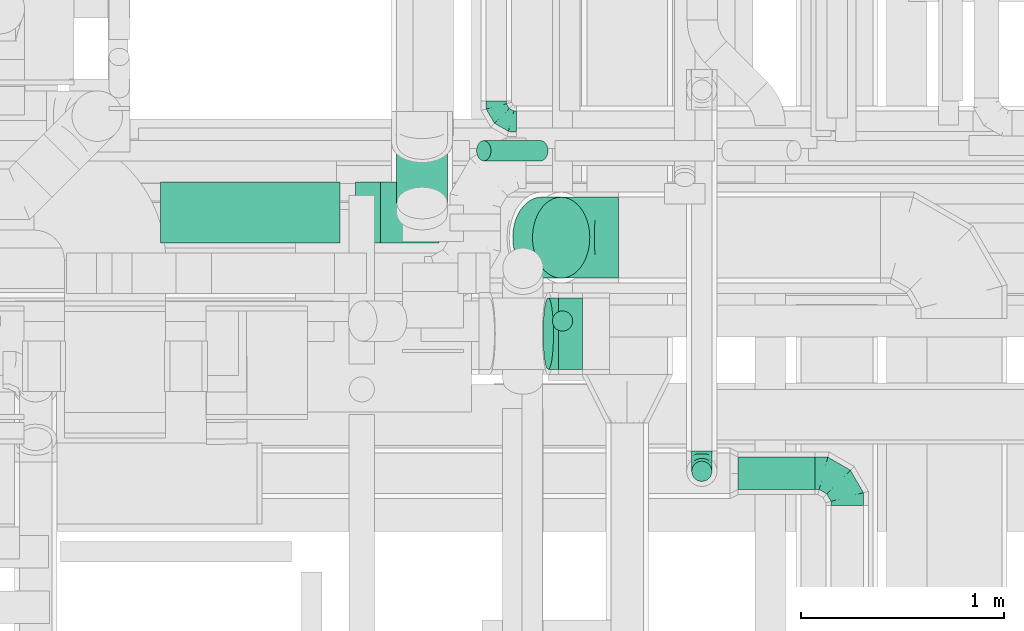
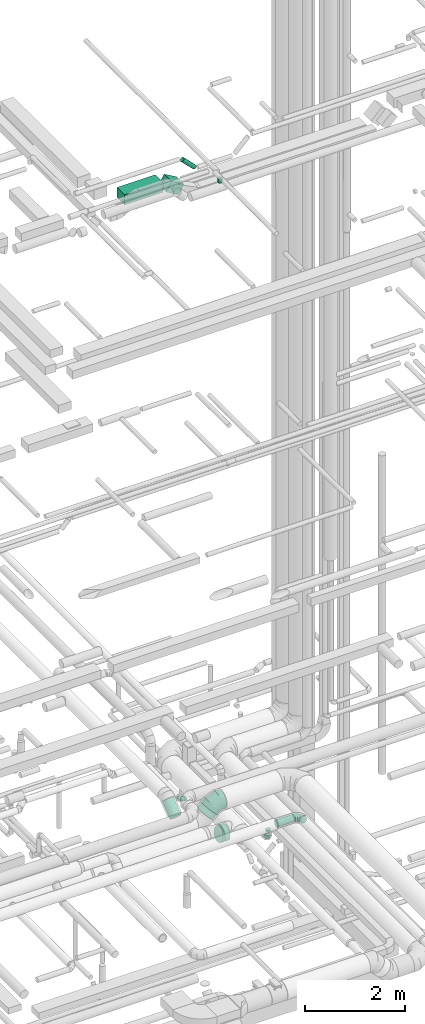
# One storey, part 254 of 337: 8 flow segments, 6 flow fittings.
"""IFC2X3 building model written with IfcOpenShell, lengths in millimetres."""

import ifcopenshell
import ifcopenshell.guid

model = None  # the IFC model being written
_history = None  # IfcOwnerHistory: only IFC2X3 demands one
_inside = {}  # id of a spatial element -> (the spatial element, [elements in it])
_under = {}  # id of a project, library or spatial element -> (it, [spatial elements below it])
_declared = {}  # id of a project -> (the project, [libraries it declares])
_typed = {}  # id of a type object -> (the type object, [elements of that type])
_made_of = {}  # id of a material, layer set ... -> (it, [elements and type objects made of it])


def new_model(schema):
    """Start an empty IFC model of exactly this schema.

    Asked for "IFC4X3", IfcOpenShell would pick the latest addendum, in which some entities
    have other attributes; the version numbers below select the first issue.
    IFC2X3 requires an IfcOwnerHistory on every rooted entity: one is made here for all.
    """
    global model, _history
    if schema == "IFC4X3":
        model = ifcopenshell.file(schema_version=(4, 3, 0, 0))
    else:
        model = ifcopenshell.file(schema=schema)
    _inside.clear()
    _under.clear()
    _declared.clear()
    _typed.clear()
    _made_of.clear()
    _history = None
    if model.schema == "IFC2X3":
        org = make("IfcOrganization", Name="unknown")
        user = make(
            "IfcPersonAndOrganization",
            ThePerson=make("IfcPerson", FamilyName="unknown"),
            TheOrganization=org,
        )
        app = make(
            "IfcApplication",
            ApplicationDeveloper=org,
            Version="unknown",
            ApplicationFullName="unknown",
            ApplicationIdentifier="unknown",
        )
        _history = make(
            "IfcOwnerHistory",
            OwningUser=user,
            OwningApplication=app,
            ChangeAction="ADDED",
            CreationDate=0,
        )
    return model


def make(cls, **values):
    """One entity of the class cls with the attributes given. An attribute that is None is left unset."""
    return model.create_entity(
        cls, **{name: value for name, value in values.items() if value is not None}
    )


def entity(cls, *values):
    """Any entity or typed value of the class cls, its attributes in the order of the schema. None: left unset."""
    e = model.create_entity(cls)
    for i, value in enumerate(values):
        if value is not None:
            e[i] = value
    return e


def rooted(cls, **values):
    """An entity with a GlobalId (a new one), such as an element, a storey or a relation."""
    return make(cls, GlobalId=ifcopenshell.guid.new(), OwnerHistory=_history, **values)


def si_unit(unit_type, name, prefix=None):
    """IfcSIUnit, for example si_unit("LENGTHUNIT", "METRE", prefix="MILLI")."""
    return make("IfcSIUnit", UnitType=unit_type, Prefix=prefix, Name=name)


def converted_unit(unit_type, name, factor, base, dimensions=None, offset=None):
    """IfcConversionBasedUnit, such as the inch: factor (a typed value) times the base unit."""
    return make(
        "IfcConversionBasedUnit"
        if offset is None
        else "IfcConversionBasedUnitWithOffset",
        ConversionOffset=offset,
        Dimensions=None
        if dimensions is None
        else entity("IfcDimensionalExponents", *dimensions),
        UnitType=unit_type,
        Name=name,
        ConversionFactor=make(
            "IfcMeasureWithUnit", ValueComponent=factor, UnitComponent=base
        ),
    )


def derived_unit(unit_type, elements):
    """IfcDerivedUnit: a product of units, each with its exponent."""
    return make(
        "IfcDerivedUnit",
        Elements=[
            make("IfcDerivedUnitElement", Unit=unit, Exponent=power)
            for unit, power in elements
        ],
        UnitType=unit_type,
    )


def assignment(units):
    """IfcUnitAssignment: the units of a project."""
    return None if units is None else make("IfcUnitAssignment", Units=units)


def point(xyz):
    """IfcCartesianPoint."""
    return None if xyz is None else make("IfcCartesianPoint", Coordinates=xyz)


def direction(xyz):
    """IfcDirection."""
    return None if xyz is None else make("IfcDirection", DirectionRatios=xyz)


def frame(location, z_axis=None, x_axis=None):
    """IfcAxis2Placement3D, a coordinate frame: its origin and axes. An axis left out is left unset."""
    return make(
        "IfcAxis2Placement3D",
        Location=point(location),
        Axis=direction(z_axis),
        RefDirection=direction(x_axis),
    )


def frame_2d(location, x_axis=None):
    """IfcAxis2Placement2D, a coordinate frame in the plane: its origin and x axis."""
    return make(
        "IfcAxis2Placement2D", Location=point(location), RefDirection=direction(x_axis)
    )


def origin():
    """The frame at (0, 0, 0) with its axes left unset."""
    return frame((0.0, 0.0, 0.0))


def origin_2d_with_axis():
    """The frame at (0, 0) in the plane with the x axis (1, 0) written out."""
    return frame_2d((0.0, 0.0), x_axis=(1.0, 0.0))


def place(relative_to, where):
    """IfcLocalPlacement: puts the frame where relative to a parent placement (None: the world)."""
    return make(
        "IfcLocalPlacement", PlacementRelTo=relative_to, RelativePlacement=where
    )


def context(
    kind, dimensions, precision=None, world=None, true_north=None, identifier=None
):
    """IfcGeometricRepresentationContext, for example the 3D "Model" context."""
    return make(
        "IfcGeometricRepresentationContext",
        ContextIdentifier=identifier,
        ContextType=kind,
        CoordinateSpaceDimension=dimensions,
        Precision=precision,
        WorldCoordinateSystem=world,
        TrueNorth=true_north,
    )


def subcontext(parent, identifier, kind, view, scale=None):
    """IfcGeometricRepresentationSubContext, for example "Body" below "Model"."""
    return make(
        "IfcGeometricRepresentationSubContext",
        ContextIdentifier=identifier,
        ContextType=kind,
        ParentContext=parent,
        TargetScale=scale,
        TargetView=view,
    )


def project(units=None, contexts=None):
    """IfcProject with its units and contexts."""
    return rooted(
        "IfcProject",
        Name="project",
        RepresentationContexts=contexts,
        UnitsInContext=assignment(units),
    )


def spatial(cls, under=None, at=None, **own):
    """A site, building, storey or space (cls), placed at a placement, below another one or the project."""
    s = rooted(cls, ObjectPlacement=at, **own)
    if under is not None:
        _under.setdefault(under.id(), (under, []))[1].append(s)
    return s


def profile(cls, at=None, kind="AREA", **sizes):
    """A parametric profile (cls). Its sizes go by their IFC names, for example OverallWidth=200.0."""
    return make(cls, ProfileType=kind, Position=at, **sizes)


def rectangle(**sizes):
    """IfcRectangleProfileDef."""
    return profile("IfcRectangleProfileDef", **sizes)


def circle(**sizes):
    """IfcCircleProfileDef."""
    return profile("IfcCircleProfileDef", **sizes)


def extrude(swept, where, along, depth):
    """IfcExtrudedAreaSolid: the profile swept, set in the frame where, extruded along a direction by depth."""
    return make(
        "IfcExtrudedAreaSolid",
        SweptArea=swept,
        Position=where,
        ExtrudedDirection=direction(along),
        Depth=depth,
    )


def faces_of(points, faces, orient=None, outer=None):
    """IfcFace entities. A face is a list of loops; a loop is a list of indices into points, from 0.

    orient and outer hold one flag for each loop. By default every Orientation is true, the
    first loop of a face is its IfcFaceOuterBound and the others are IfcFaceBound.
    """
    made = []
    for i, loops in enumerate(faces):
        bounds = []
        for j, loop in enumerate(loops):
            is_outer = j == 0 if outer is None else outer[i][j]
            bounds.append(
                make(
                    "IfcFaceOuterBound" if is_outer else "IfcFaceBound",
                    Bound=make("IfcPolyLoop", Polygon=[points[k] for k in loop]),
                    Orientation=True if orient is None else orient[i][j],
                )
            )
        made.append(make("IfcFace", Bounds=bounds))
    return made


def faceted_brep(points, faces, orient=None, outer=None, voids=None):
    """IfcFacetedBrep: a solid bounded by flat faces; with voids (closed shells), ...WithVoids."""
    shared = [point(p) for p in points]
    hull = make("IfcClosedShell", CfsFaces=faces_of(shared, faces, orient, outer))
    if voids is None:
        return make("IfcFacetedBrep", Outer=hull)
    return make(
        "IfcFacetedBrepWithVoids",
        Outer=hull,
        Voids=[
            make(cls, CfsFaces=faces_of(shared, fs, o, b)) for cls, fs, o, b in voids
        ],
    )


def shape(context_of_items, identifier, shape_type, items):
    """IfcShapeRepresentation: the items that make up one representation, for example the "Body"."""
    return make(
        "IfcShapeRepresentation",
        ContextOfItems=context_of_items,
        RepresentationIdentifier=identifier,
        RepresentationType=shape_type,
        Items=items,
    )


def source(mapping_origin, context_of_items, identifier, shape_type, items):
    """IfcRepresentationMap: a shape defined once, which mapped items show again and again."""
    return make(
        "IfcRepresentationMap",
        MappingOrigin=mapping_origin,
        MappedRepresentation=shape(context_of_items, identifier, shape_type, items),
    )


def transform(
    local_origin,
    x_axis=None,
    y_axis=None,
    z_axis=None,
    scale=None,
    scale2=None,
    scale3=None,
    uniform=True,
):
    """IfcCartesianTransformationOperator3D, or its non-uniform kind. x_axis, y_axis, z_axis: its Axis1, 2, 3."""
    if uniform:
        return make(
            "IfcCartesianTransformationOperator3D",
            Axis1=direction(x_axis),
            Axis2=direction(y_axis),
            LocalOrigin=point(local_origin),
            Scale=scale,
            Axis3=direction(z_axis),
        )
    return make(
        "IfcCartesianTransformationOperator3DnonUniform",
        Axis1=direction(x_axis),
        Axis2=direction(y_axis),
        LocalOrigin=point(local_origin),
        Scale=scale,
        Axis3=direction(z_axis),
        Scale2=scale2,
        Scale3=scale3,
    )


def mapped(mapping_source, mapping_target):
    """IfcMappedItem: shows the shape of a source again, moved by a transform."""
    return make(
        "IfcMappedItem", MappingSource=mapping_source, MappingTarget=mapping_target
    )


def material(Name=None, Category=None):
    """IfcMaterial."""
    return make("IfcMaterial", Name=Name, Category=Category)


def made_of(thing, what):
    """Note that an element or type object is made of a material, layer set ...; save() writes the relation."""
    if what is not None:
        _made_of.setdefault(what.id(), (what, []))[1].append(thing)
    return thing


def type_object(cls, material=None, **own):
    """A type object (cls), such as IfcWallType, which elements share."""
    return made_of(rooted(cls, **own), material)


def type_shapes(of_type, sources):
    """Give a type object the sources (RepresentationMaps) that its elements show as mapped items."""
    of_type.RepresentationMaps = sources


def element(
    cls,
    number,
    at=None,
    inside=None,
    cuts=None,
    type_object=None,
    material=None,
    context=None,
    identifier="Body",
    shape_type=None,
    held_by="IfcProductDefinitionShape",
    body=None,
    shapes=None,
    **own,
):
    """One element of the class cls, such as IfcWall. Its Tag is "e" and its number.

    at: its placement. inside: the storey or other place that contains it. cuts: it is an
    opening in that element (IfcRelVoidsElement). A single representation is given by context,
    identifier, shape_type and body (its items); several are given by shapes. held_by: the class
    of the entity that holds the representations. save() writes the other relations.
    """
    e = rooted(cls, Tag="e%d" % number, ObjectPlacement=at, **own)
    if body is not None:
        shapes = [shape(context, identifier, shape_type, body)]
    if shapes is not None:
        e.Representation = make(held_by, Representations=shapes)
    if inside is not None:
        _inside.setdefault(inside.id(), (inside, []))[1].append(e)
    if cuts is not None:
        rooted(
            "IfcRelVoidsElement", RelatingBuildingElement=cuts, RelatedOpeningElement=e
        )
    if type_object is not None:
        _typed.setdefault(type_object.id(), (type_object, []))[1].append(e)
    return made_of(e, material)


def aggregate(whole, parts):
    """IfcRelAggregates: a whole, such as a stair, and the parts it consists of."""
    return rooted("IfcRelAggregates", RelatingObject=whole, RelatedObjects=parts)


def save(model, path):
    """Write the relations noted so far, then the file.

    IfcRelAggregates (storeys below a building ...), IfcRelContainedInSpatialStructure (elements
    in a storey), IfcRelDefinesByType, IfcRelAssociatesMaterial and IfcRelDeclares: one each for
    every whole, place, type object, material and project.
    """
    for whole, parts in _under.values():
        aggregate(whole, parts)
    for where, things in _inside.values():
        rooted(
            "IfcRelContainedInSpatialStructure",
            RelatedElements=things,
            RelatingStructure=where,
        )
    for kind, things in _typed.values():
        rooted("IfcRelDefinesByType", RelatedObjects=things, RelatingType=kind)
    for what, things in _made_of.values():
        rooted("IfcRelAssociatesMaterial", RelatedObjects=things, RelatingMaterial=what)
    for by, libraries in _declared.values():
        rooted("IfcRelDeclares", RelatingContext=by, RelatedDefinitions=libraries)
    model.write(path)


model = new_model("IFC2X3")

# Units and contexts
model_context = context("Model", 3, precision=0.01, world=origin(), true_north=direction((6.12303176911189e-17, 1.0)))
body_context = subcontext(model_context, "Body", "Model", "MODEL_VIEW")
ifc_project = project(units=[si_unit("LENGTHUNIT", "METRE", prefix="MILLI"), si_unit("AREAUNIT", "SQUARE_METRE"), si_unit("VOLUMEUNIT", "CUBIC_METRE"), converted_unit("PLANEANGLEUNIT", "DEGREE", entity("IfcRatioMeasure", 0.0174532925199433), si_unit("PLANEANGLEUNIT", "RADIAN"), dimensions=[0, 0, 0, 0, 0, 0, 0]), si_unit("MASSUNIT", "GRAM", prefix="KILO"), derived_unit("MASSDENSITYUNIT", [(si_unit("MASSUNIT", "GRAM", prefix="KILO"), 1), (si_unit("LENGTHUNIT", "METRE"), -3)]), derived_unit("MOMENTOFINERTIAUNIT", [(si_unit("LENGTHUNIT", "METRE"), 4)]), si_unit("TIMEUNIT", "SECOND"), si_unit("FREQUENCYUNIT", "HERTZ"), si_unit("THERMODYNAMICTEMPERATUREUNIT", "DEGREE_CELSIUS"), derived_unit("THERMALTRANSMITTANCEUNIT", [(si_unit("MASSUNIT", "GRAM", prefix="KILO"), 1), (si_unit("THERMODYNAMICTEMPERATUREUNIT", "KELVIN"), -1), (si_unit("TIMEUNIT", "SECOND"), -3)]), derived_unit("VOLUMETRICFLOWRATEUNIT", [(si_unit("LENGTHUNIT", "METRE"), 3), (si_unit("TIMEUNIT", "SECOND"), -1)]), derived_unit("MASSFLOWRATEUNIT", [(si_unit("MASSUNIT", "GRAM", prefix="KILO"), 1), (si_unit("TIMEUNIT", "SECOND"), -1)]), derived_unit("ROTATIONALFREQUENCYUNIT", [(si_unit("TIMEUNIT", "SECOND"), -1)]), si_unit("ELECTRICCURRENTUNIT", "AMPERE"), si_unit("ELECTRICVOLTAGEUNIT", "VOLT"), si_unit("POWERUNIT", "WATT"), si_unit("FORCEUNIT", "NEWTON", prefix="KILO"), si_unit("ILLUMINANCEUNIT", "LUX"), si_unit("LUMINOUSFLUXUNIT", "LUMEN"), si_unit("LUMINOUSINTENSITYUNIT", "CANDELA"), derived_unit("USERDEFINED", [(si_unit("MASSUNIT", "GRAM", prefix="KILO"), -1), (si_unit("LENGTHUNIT", "METRE"), -2), (si_unit("TIMEUNIT", "SECOND"), 3), (si_unit("LUMINOUSFLUXUNIT", "LUMEN"), 1)]), derived_unit("LINEARVELOCITYUNIT", [(si_unit("LENGTHUNIT", "METRE"), 1), (si_unit("TIMEUNIT", "SECOND"), -1)]), si_unit("PRESSUREUNIT", "PASCAL"), derived_unit("USERDEFINED", [(si_unit("LENGTHUNIT", "METRE"), -2), (si_unit("MASSUNIT", "GRAM", prefix="KILO"), 1), (si_unit("TIMEUNIT", "SECOND"), -2)]), derived_unit("LINEARFORCEUNIT", [(si_unit("MASSUNIT", "GRAM", prefix="KILO"), 1), (si_unit("LENGTHUNIT", "METRE"), 1), (si_unit("TIMEUNIT", "SECOND"), -2), (si_unit("LENGTHUNIT", "METRE"), -1)]), derived_unit("PLANARFORCEUNIT", [(si_unit("MASSUNIT", "GRAM", prefix="KILO"), 1), (si_unit("LENGTHUNIT", "METRE"), 1), (si_unit("TIMEUNIT", "SECOND"), -2), (si_unit("LENGTHUNIT", "METRE"), -2)])], contexts=[model_context])

# Site, building, storey
site_placement = place(None, origin())
site = spatial("IfcSite", under=ifc_project, at=site_placement, CompositionType="ELEMENT")
building_placement = place(site_placement, origin())
building = spatial("IfcBuilding", under=site, at=building_placement, CompositionType="ELEMENT")
storey_placement = place(building_placement, origin())
storey = spatial("IfcBuildingStorey", under=building, at=storey_placement, CompositionType="ELEMENT", Elevation=0.0)

# Flow segments
duct_segment_type_1 = type_object("IfcDuctSegmentType", PredefinedType="NOTDEFINED")
flow_segment_1_placement = place(storey_placement, frame((62344.65, 9724.07, 18850.0)))
element("IfcFlowSegment", 1, at=flow_segment_1_placement, inside=storey, type_object=duct_segment_type_1, context=body_context, shape_type="SweptSolid", body=[
    extrude(rectangle(XDim=886.526564663121, YDim=300.0, at=origin_2d_with_axis()), frame((443.26, 150.0, 0.0)), (0.0, 0.0, 1.0), 249.999999999999),
])
flow_segment_2_placement = place(storey_placement, frame((63306.03, 9724.07, 18663.36)))
element("IfcFlowSegment", 2, at=flow_segment_2_placement, inside=storey, type_object=duct_segment_type_1, context=body_context, shape_type="SweptSolid", body=[
    extrude(rectangle(XDim=250.000000000003, YDim=300.0, at=frame_2d((0.0, 0.0), x_axis=(0.0, 1.0))), frame((62.38, 150.0, 274.95), z_axis=(0.86659261286726, 0.0, -0.499016275610221), x_axis=(0.0, 1.0, 0.0)), (0.0, 0.0, 1.0), 333.908822659735),
])
duct_segment_type_2 = type_object("IfcDuctSegmentType", PredefinedType="NOTDEFINED")
flow_segment_3_placement = place(storey_placement, frame((64277.72, 9286.98, 18955.0)))
element("IfcFlowSegment", 3, at=flow_segment_3_placement, inside=storey, type_object=duct_segment_type_2, context=body_context, shape_type="SweptSolid", body=[
    extrude(circle(Radius=50.0, at=origin_2d_with_axis()), frame((51.6, 51.6, 0.0)), (0.0, 0.0, 1.0), 94.9999999999871),
])
flow_segment_4_placement = place(storey_placement, frame((63903.4, 10127.45, 18812.34)))
element("IfcFlowSegment", 4, at=flow_segment_4_placement, inside=storey, type_object=duct_segment_type_2, context=body_context, shape_type="SweptSolid", body=[
    extrude(circle(Radius=50.0, at=origin_2d_with_axis()), frame((318.37, 51.6, 36.95), z_axis=(-0.707106781186552, 0.0, 0.707106781186543), x_axis=(0.0, 1.0, 0.0)), (0.0, 0.0, 1.0), 397.989898732217),
])
flow_segment_5_placement = place(storey_placement, frame((64081.65, 9548.4, 3142.18)))
element("IfcFlowSegment", 5, at=flow_segment_5_placement, inside=storey, type_object=duct_segment_type_2, context=body_context, shape_type="SweptSolid", body=[
    extrude(circle(Radius=200.0, at=origin_2d_with_axis()), frame((143.02, 201.6, 143.02), z_axis=(0.707106759953313, 0.0, 0.707106802419781), x_axis=(0.0, 1.0, 0.0)), (0.0, 0.0, 1.0), 138.093806996356),
])
flow_segment_6_placement = place(storey_placement, frame((64310.17, 9096.79, 2870.9)))
element("IfcFlowSegment", 6, at=flow_segment_6_placement, inside=storey, type_object=duct_segment_type_2, context=body_context, shape_type="SweptSolid", body=[
    extrude(circle(Radius=177.5, at=origin_2d_with_axis()), frame((0.0, 179.1, 179.1), z_axis=(1.0, 0.0, 0.0), x_axis=(0.0, 1.0, 0.0)), (0.0, 0.0, 1.0), 118.097986558883),
])
flow_segment_7_placement = place(storey_placement, frame((65196.4, 8505.07, 3318.4)))
element("IfcFlowSegment", 7, at=flow_segment_7_placement, inside=storey, type_object=duct_segment_type_2, context=body_context, shape_type="SweptSolid", body=[
    extrude(circle(Radius=80.0, at=origin_2d_with_axis()), frame((0.0, 81.6, 81.6), z_axis=(1.0, 0.0, 0.0), x_axis=(0.0, -1.0, 0.0)), (0.0, 0.0, 1.0), 378.271123421161),
])
flow_segment_8_placement = place(storey_placement, frame((63508.85, 9840.74, 3207.72)))
element("IfcFlowSegment", 8, at=flow_segment_8_placement, inside=storey, type_object=duct_segment_type_2, context=body_context, shape_type="SweptSolid", body=[
    extrude(circle(Radius=125.0, at=origin_2d_with_axis()), frame((126.6, 80.25, 98.75), z_axis=(0.0, 0.777218163674396, 0.629231218277192), x_axis=(1.0, 0.0, 0.0)), (0.0, 0.0, 1.0), 377.977646889818),
])

# Flow fittings
ifc_material = material()
duct_fitting_type_1 = type_object("IfcDuctFittingType", PredefinedType="NOTDEFINED", material=ifc_material)
shared_shape_1 = source(origin(), body_context, "Body", "Brep", [
    faceted_brep([(-160.0, 0.0, -80.0), (-160.0, -20.71, -77.27), (-160.0, -40.0, -69.28), (-160.0, -56.57, -56.57), (-160.0, -69.28, -40.0), (-160.0, -77.27, -20.71), (-160.0, -80.0, 0.0), (-160.0, -77.27, 20.71), (-160.0, -69.28, 40.0), (-160.0, -56.57, 56.57), (-160.0, -40.0, 69.28), (-160.0, -20.71, 77.27), (-160.0, 0.0, 80.0), (-160.0, 20.71, 77.27), (-160.0, 40.0, 69.28), (-160.0, 56.57, 56.57), (-160.0, 69.28, 40.0), (-160.0, 77.27, 20.71), (-160.0, 80.0, 0.0), (-160.0, 77.27, -20.71), (-160.0, 69.28, -40.0), (-160.0, 56.57, -56.57), (-160.0, 40.0, -69.28), (-160.0, 20.71, -77.27), (-122.68, 20.71, 77.27), (-127.85, 40.0, 69.28), (-117.13, 0.0, 80.0), (-132.29, 56.57, 56.57), (-137.83, 77.27, 20.71), (-138.56, 80.0, 0.0), (-135.69, 69.28, 40.0), (-135.69, 69.28, -40.0), (-132.29, 56.57, -56.57), (-137.83, 77.27, -20.71), (-122.68, 20.71, -77.27), (-117.13, 0.0, -80.0), (-127.85, 40.0, -69.28), (-111.58, -20.71, -77.27), (-106.41, -40.0, -69.28), (-101.97, -56.57, -56.57), (-98.56, -69.28, -40.0), (-96.42, -77.27, -20.71), (-95.69, -80.0, 0.0), (-96.42, -77.27, 20.71), (-98.56, -69.28, 40.0), (-101.97, -56.57, 56.57), (-106.41, -40.0, 69.28), (-111.58, -20.71, 77.27), (-58.03, 58.03, 77.27), (-72.15, 72.15, 69.28), (-42.87, 42.87, 80.0), (-84.28, 84.28, 56.57), (-93.59, 93.59, 40.0), (-99.44, 99.44, 20.71), (-101.44, 101.44, 0.0), (-99.44, 99.44, -20.71), (-93.59, 93.59, -40.0), (-84.28, 84.28, -56.57), (-58.03, 58.03, -77.27), (-42.87, 42.87, -80.0), (-72.15, 72.15, -69.28), (-27.71, 27.71, -77.27), (-13.59, 13.59, -69.28), (-1.46, 1.46, -56.57), (7.85, -7.85, -40.0), (13.7, -13.7, -20.71), (15.69, -15.69, 0.0), (13.7, -13.7, 20.71), (7.85, -7.85, 40.0), (-1.46, 1.46, 56.57), (-13.59, 13.59, 69.28), (-27.71, 27.71, 77.27), (-20.71, 122.68, 77.27), (-40.0, 127.85, 69.28), (0.0, 117.13, 80.0), (-56.57, 132.29, 56.57), (-69.28, 135.69, 40.0), (-77.27, 137.83, 20.71), (-80.0, 138.56, 0.0), (-77.27, 137.83, -20.71), (-69.28, 135.69, -40.0), (-56.57, 132.29, -56.57), (-20.71, 122.68, -77.27), (0.0, 117.13, -80.0), (-40.0, 127.85, -69.28), (20.71, 111.58, -77.27), (40.0, 106.41, -69.28), (56.57, 101.97, -56.57), (69.28, 98.56, -40.0), (77.27, 96.42, -20.71), (80.0, 95.69, 0.0), (77.27, 96.42, 20.71), (69.28, 98.56, 40.0), (56.57, 101.97, 56.57), (40.0, 106.41, 69.28), (20.71, 111.58, 77.27), (-20.71, 160.0, -77.27), (-40.0, 160.0, -69.28), (-56.57, 160.0, -56.57), (-69.28, 160.0, -40.0), (-77.27, 160.0, -20.71), (-80.0, 160.0, 0.0), (-77.27, 160.0, 20.71), (-69.28, 160.0, 40.0), (-56.57, 160.0, 56.57), (-40.0, 160.0, 69.28), (-20.71, 160.0, 77.27), (0.0, 160.0, 80.0), (20.71, 160.0, 77.27), (40.0, 160.0, 69.28), (56.57, 160.0, 56.57), (69.28, 160.0, 40.0), (77.27, 160.0, 20.71), (80.0, 160.0, 0.0), (77.27, 160.0, -20.71), (69.28, 160.0, -40.0), (56.57, 160.0, -56.57), (40.0, 160.0, -69.28), (20.71, 160.0, -77.27), (0.0, 160.0, -80.0)], [[[0, 1, 2, 3, 4, 5, 6, 7, 8, 9, 10, 11, 12, 13, 14, 15, 16, 17, 18, 19, 20, 21, 22, 23]], [[24, 25, 14, 13]], [[26, 24, 13, 12]], [[14, 25, 27, 15]], [[28, 29, 18, 17]], [[30, 28, 17, 16]], [[15, 27, 30, 16]], [[20, 31, 32, 21]], [[33, 31, 20, 19]], [[18, 29, 33, 19]], [[34, 35, 0, 23]], [[36, 34, 23, 22]], [[32, 36, 22, 21]], [[1, 0, 35, 37]], [[2, 1, 37, 38]], [[3, 2, 38, 39]], [[5, 4, 40, 41]], [[6, 5, 41, 42]], [[39, 40, 4, 3]], [[6, 42, 43, 7]], [[7, 43, 44, 8]], [[8, 44, 45, 9]], [[9, 45, 46, 10]], [[10, 46, 47, 11]], [[26, 12, 11, 47]], [[48, 49, 25, 24]], [[50, 48, 24, 26]], [[27, 25, 49, 51]], [[52, 53, 28, 30]], [[51, 52, 30, 27]], [[29, 28, 53, 54]], [[55, 56, 31, 33]], [[54, 55, 33, 29]], [[32, 31, 56, 57]], [[58, 59, 35, 34]], [[60, 58, 34, 36]], [[57, 60, 36, 32]], [[37, 35, 59, 61]], [[38, 37, 61, 62]], [[39, 38, 62, 63]], [[41, 40, 64, 65]], [[42, 41, 65, 66]], [[63, 64, 40, 39]], [[43, 42, 66, 67]], [[44, 43, 67, 68]], [[68, 69, 45, 44]], [[46, 45, 69, 70]], [[47, 46, 70, 71]], [[26, 47, 71, 50]], [[72, 73, 49, 48]], [[74, 72, 48, 50]], [[51, 49, 73, 75]], [[76, 77, 53, 52]], [[75, 76, 52, 51]], [[54, 53, 77, 78]], [[79, 80, 56, 55]], [[78, 79, 55, 54]], [[57, 56, 80, 81]], [[82, 83, 59, 58]], [[84, 82, 58, 60]], [[81, 84, 60, 57]], [[61, 59, 83, 85]], [[62, 61, 85, 86]], [[63, 62, 86, 87]], [[65, 64, 88, 89]], [[66, 65, 89, 90]], [[87, 88, 64, 63]], [[67, 66, 90, 91]], [[68, 67, 91, 92]], [[92, 93, 69, 68]], [[70, 69, 93, 94]], [[71, 70, 94, 95]], [[50, 71, 95, 74]], [[96, 97, 98, 99, 100, 101, 102, 103, 104, 105, 106, 107, 108, 109, 110, 111, 112, 113, 114, 115, 116, 117, 118, 119]], [[72, 74, 107, 106]], [[73, 72, 106, 105]], [[75, 73, 105, 104]], [[77, 76, 103, 102]], [[78, 77, 102, 101]], [[75, 104, 103, 76]], [[78, 101, 100, 79]], [[79, 100, 99, 80]], [[80, 99, 98, 81]], [[84, 97, 96, 82]], [[82, 96, 119, 83]], [[84, 81, 98, 97]], [[118, 117, 86, 85]], [[119, 118, 85, 83]], [[116, 87, 86, 117]], [[88, 115, 114, 89]], [[89, 114, 113, 90]], [[115, 88, 87, 116]], [[112, 111, 92, 91]], [[113, 112, 91, 90]], [[111, 110, 93, 92]], [[95, 94, 109, 108]], [[74, 95, 108, 107]], [[110, 109, 94, 93]]]),
])
type_shapes(duct_fitting_type_1, [shared_shape_1])
flow_fitting_1_placement = place(storey_placement, frame((65734.68, 8586.67, 3400.0), z_axis=(0.0, 0.0, 1.0), x_axis=(0.0, 1.0, 0.0)))
element("IfcFlowFitting", 9, at=flow_fitting_1_placement, inside=storey, type_object=duct_fitting_type_1, material=ifc_material, context=body_context, shape_type="MappedRepresentation", body=[
    mapped(shared_shape_1, transform((0.0, 0.0, 0.0), scale=1.0)),
])
duct_fitting_type_2 = type_object("IfcDuctFittingType", PredefinedType="NOTDEFINED", material=ifc_material)
shared_shape_2 = source(origin(), body_context, "Body", "Brep", [
    faceted_brep([(-100.0, 0.0, -50.0), (-100.0, -12.94, -48.3), (-100.0, -25.0, -43.3), (-100.0, -35.36, -35.36), (-100.0, -43.3, -25.0), (-100.0, -48.3, -12.94), (-100.0, -50.0, 0.0), (-100.0, -48.3, 12.94), (-100.0, -43.3, 25.0), (-100.0, -35.36, 35.36), (-100.0, -25.0, 43.3), (-100.0, -12.94, 48.3), (-100.0, 0.0, 50.0), (-100.0, 12.94, 48.3), (-100.0, 25.0, 43.3), (-100.0, 35.36, 35.36), (-100.0, 43.3, 25.0), (-100.0, 48.3, 12.94), (-100.0, 50.0, 0.0), (-100.0, 48.3, -12.94), (-100.0, 43.3, -25.0), (-100.0, 35.36, -35.36), (-100.0, 25.0, -43.3), (-100.0, 12.94, -48.3), (-76.67, 12.94, 48.3), (-79.9, 25.0, 43.3), (-73.21, 0.0, 50.0), (-82.68, 35.36, 35.36), (-86.15, 48.3, 12.94), (-86.6, 50.0, 0.0), (-84.81, 43.3, 25.0), (-84.81, 43.3, -25.0), (-82.68, 35.36, -35.36), (-86.15, 48.3, -12.94), (-76.67, 12.94, -48.3), (-73.21, 0.0, -50.0), (-79.9, 25.0, -43.3), (-69.74, -12.94, -48.3), (-66.51, -25.0, -43.3), (-63.73, -35.36, -35.36), (-61.6, -43.3, -25.0), (-60.26, -48.3, -12.94), (-59.81, -50.0, 0.0), (-60.26, -48.3, 12.94), (-61.6, -43.3, 25.0), (-63.73, -35.36, 35.36), (-66.51, -25.0, 43.3), (-69.74, -12.94, 48.3), (-36.27, 36.27, 48.3), (-45.1, 45.1, 43.3), (-26.79, 26.79, 50.0), (-52.68, 52.68, 35.36), (-58.49, 58.49, 25.0), (-62.15, 62.15, 12.94), (-63.4, 63.4, 0.0), (-62.15, 62.15, -12.94), (-58.49, 58.49, -25.0), (-52.68, 52.68, -35.36), (-36.27, 36.27, -48.3), (-26.79, 26.79, -50.0), (-45.1, 45.1, -43.3), (-17.32, 17.32, -48.3), (-8.49, 8.49, -43.3), (-0.91, 0.91, -35.36), (4.9, -4.9, -25.0), (8.56, -8.56, -12.94), (9.81, -9.81, 0.0), (8.56, -8.56, 12.94), (4.9, -4.9, 25.0), (-0.91, 0.91, 35.36), (-8.49, 8.49, 43.3), (-17.32, 17.32, 48.3), (-12.94, 76.67, 48.3), (-25.0, 79.9, 43.3), (0.0, 73.21, 50.0), (-35.36, 82.68, 35.36), (-43.3, 84.81, 25.0), (-48.3, 86.15, 12.94), (-50.0, 86.6, 0.0), (-48.3, 86.15, -12.94), (-43.3, 84.81, -25.0), (-35.36, 82.68, -35.36), (-12.94, 76.67, -48.3), (0.0, 73.21, -50.0), (-25.0, 79.9, -43.3), (12.94, 69.74, -48.3), (25.0, 66.51, -43.3), (35.36, 63.73, -35.36), (43.3, 61.6, -25.0), (48.3, 60.26, -12.94), (50.0, 59.81, 0.0), (48.3, 60.26, 12.94), (43.3, 61.6, 25.0), (35.36, 63.73, 35.36), (25.0, 66.51, 43.3), (12.94, 69.74, 48.3), (-12.94, 100.0, -48.3), (-25.0, 100.0, -43.3), (-35.36, 100.0, -35.36), (-43.3, 100.0, -25.0), (-48.3, 100.0, -12.94), (-50.0, 100.0, 0.0), (-48.3, 100.0, 12.94), (-43.3, 100.0, 25.0), (-35.36, 100.0, 35.36), (-25.0, 100.0, 43.3), (-12.94, 100.0, 48.3), (0.0, 100.0, 50.0), (12.94, 100.0, 48.3), (25.0, 100.0, 43.3), (35.36, 100.0, 35.36), (43.3, 100.0, 25.0), (48.3, 100.0, 12.94), (50.0, 100.0, 0.0), (48.3, 100.0, -12.94), (43.3, 100.0, -25.0), (35.36, 100.0, -35.36), (25.0, 100.0, -43.3), (12.94, 100.0, -48.3), (0.0, 100.0, -50.0)], [[[0, 1, 2, 3, 4, 5, 6, 7, 8, 9, 10, 11, 12, 13, 14, 15, 16, 17, 18, 19, 20, 21, 22, 23]], [[24, 25, 14, 13]], [[26, 24, 13, 12]], [[14, 25, 27, 15]], [[28, 29, 18, 17]], [[30, 28, 17, 16]], [[15, 27, 30, 16]], [[20, 31, 32, 21]], [[33, 31, 20, 19]], [[18, 29, 33, 19]], [[34, 35, 0, 23]], [[36, 34, 23, 22]], [[32, 36, 22, 21]], [[2, 1, 37, 38]], [[3, 2, 38, 39]], [[0, 35, 37, 1]], [[5, 4, 40, 41]], [[6, 5, 41, 42]], [[3, 39, 40, 4]], [[6, 42, 43, 7]], [[7, 43, 44, 8]], [[8, 44, 45, 9]], [[10, 46, 47, 11]], [[11, 47, 26, 12]], [[10, 9, 45, 46]], [[48, 49, 25, 24]], [[50, 48, 24, 26]], [[27, 25, 49, 51]], [[52, 53, 28, 30]], [[51, 52, 30, 27]], [[29, 28, 53, 54]], [[55, 56, 31, 33]], [[54, 55, 33, 29]], [[57, 32, 31, 56]], [[58, 59, 35, 34]], [[60, 58, 34, 36]], [[57, 60, 36, 32]], [[37, 35, 59, 61]], [[38, 37, 61, 62]], [[39, 38, 62, 63]], [[41, 40, 64, 65]], [[42, 41, 65, 66]], [[63, 64, 40, 39]], [[43, 42, 66, 67]], [[44, 43, 67, 68]], [[68, 69, 45, 44]], [[46, 45, 69, 70]], [[47, 46, 70, 71]], [[26, 47, 71, 50]], [[72, 73, 49, 48]], [[74, 72, 48, 50]], [[51, 49, 73, 75]], [[76, 77, 53, 52]], [[75, 76, 52, 51]], [[54, 53, 77, 78]], [[79, 80, 56, 55]], [[78, 79, 55, 54]], [[81, 57, 56, 80]], [[82, 83, 59, 58]], [[84, 82, 58, 60]], [[81, 84, 60, 57]], [[61, 59, 83, 85]], [[62, 61, 85, 86]], [[63, 62, 86, 87]], [[65, 64, 88, 89]], [[66, 65, 89, 90]], [[87, 88, 64, 63]], [[67, 66, 90, 91]], [[68, 67, 91, 92]], [[92, 93, 69, 68]], [[70, 69, 93, 94]], [[71, 70, 94, 95]], [[50, 71, 95, 74]], [[96, 97, 98, 99, 100, 101, 102, 103, 104, 105, 106, 107, 108, 109, 110, 111, 112, 113, 114, 115, 116, 117, 118, 119]], [[72, 74, 107, 106]], [[73, 72, 106, 105]], [[75, 73, 105, 104]], [[77, 76, 103, 102]], [[78, 77, 102, 101]], [[75, 104, 103, 76]], [[78, 101, 100, 79]], [[79, 100, 99, 80]], [[80, 99, 98, 81]], [[96, 119, 83, 82]], [[97, 96, 82, 84]], [[84, 81, 98, 97]], [[83, 119, 118, 85]], [[85, 118, 117, 86]], [[86, 117, 116, 87]], [[88, 115, 114, 89]], [[89, 114, 113, 90]], [[87, 116, 115, 88]], [[91, 90, 113, 112]], [[92, 91, 112, 111]], [[93, 92, 111, 110]], [[95, 94, 109, 108]], [[74, 95, 108, 107]], [[110, 109, 94, 93]]]),
])
type_shapes(duct_fitting_type_2, [shared_shape_2])
for number, where, z_axis, x_axis in (
    (10, (64002.18, 10324.99, 3350.0), (0.0, 0.0, 1.0), (0.0, -1.0, 0.0)),
    (11, (65016.74, 8596.67, 3100.0), (1.0, 0.0, 0.0), (0.0, 0.0, -1.0)),
):
    element("IfcFlowFitting", number, at=place(storey_placement, frame(where, z_axis=z_axis, x_axis=x_axis)), inside=storey, type_object=duct_fitting_type_2, material=ifc_material, context=body_context, shape_type="MappedRepresentation", body=[
        mapped(shared_shape_2, transform((0.0, 0.0, 0.0), scale=1.0)),
    ])
duct_fitting_type_3 = type_object("IfcDuctFittingType", PredefinedType="NOTDEFINED", material=ifc_material)
shared_shape_3 = source(origin(), body_context, "Body", "Brep", [
    faceted_brep([(20.0, 12.94, -48.3), (20.0, 25.0, -43.3), (20.0, 35.36, -35.36), (20.0, 43.3, -25.0), (20.0, 48.3, -12.94), (20.0, 50.0, 0.0), (20.0, 48.3, 12.94), (20.0, 43.3, 25.0), (20.0, 35.36, 35.36), (20.0, 25.0, 43.3), (20.0, 12.94, 48.3), (20.0, 0.0, 50.0), (20.0, -12.94, 48.3), (20.0, -25.0, 43.3), (20.0, -35.36, 35.36), (20.0, -43.3, 25.0), (20.0, -48.3, 12.94), (20.0, -50.0, 0.0), (20.0, -48.3, -12.94), (20.0, -43.3, -25.0), (20.0, -35.36, -35.36), (20.0, -25.0, -43.3), (20.0, -12.94, -48.3), (20.0, 0.0, -50.0), (0.0, 0.0, 50.0), (0.0, 12.94, 48.3), (-25.59, 12.94, 48.3), (-25.59, 0.0, 50.0), (0.0, 25.0, 43.3), (-25.59, 25.0, 43.3), (0.0, 35.36, 35.36), (-25.59, 35.36, 35.36), (0.0, 43.3, 25.0), (0.0, 48.3, 12.94), (-25.59, 48.3, 12.94), (-25.59, 43.3, 25.0), (0.0, 50.0, 0.0), (-25.59, 50.0, 0.0), (0.0, 48.3, -12.94), (-25.59, 48.3, -12.94), (0.0, 43.3, -25.0), (-25.59, 43.3, -25.0), (0.0, 35.36, -35.36), (-25.59, 35.36, -35.36), (0.0, 25.0, -43.3), (0.0, 12.94, -48.3), (-25.59, 12.94, -48.3), (-25.59, 25.0, -43.3), (0.0, 0.0, -50.0), (-25.59, 0.0, -50.0), (0.0, -12.94, -48.3), (-25.59, -12.94, -48.3), (0.0, -25.0, -43.3), (-25.59, -25.0, -43.3), (0.0, -35.36, -35.36), (-25.59, -35.36, -35.36), (0.0, -43.3, -25.0), (0.0, -48.3, -12.94), (-25.59, -48.3, -12.94), (-25.59, -43.3, -25.0), (0.0, -50.0, 0.0), (-25.59, -50.0, 0.0), (0.0, -48.3, 12.94), (-25.59, -48.3, 12.94), (0.0, -43.3, 25.0), (-25.59, -43.3, 25.0), (0.0, -35.36, 35.36), (-25.59, -35.36, 35.36), (0.0, -25.0, 43.3), (0.0, -12.94, 48.3), (-25.59, -12.94, 48.3), (-25.59, -25.0, 43.3)], [[[0, 1, 2, 3, 4, 5, 6, 7, 8, 9, 10, 11, 12, 13, 14, 15, 16, 17, 18, 19, 20, 21, 22, 23]], [[24, 11, 10, 25, 26, 27]], [[25, 10, 9, 28, 29, 26]], [[28, 9, 8, 30, 31, 29]], [[32, 7, 6, 33, 34, 35]], [[33, 6, 5, 36, 37, 34]], [[30, 8, 7, 32, 35, 31]], [[36, 5, 4, 38, 39, 37]], [[38, 4, 3, 40, 41, 39]], [[40, 3, 2, 42, 43, 41]], [[44, 1, 0, 45, 46, 47]], [[45, 0, 23, 48, 49, 46]], [[42, 2, 1, 44, 47, 43]], [[48, 23, 22, 50, 51, 49]], [[50, 22, 21, 52, 53, 51]], [[52, 21, 20, 54, 55, 53]], [[56, 19, 18, 57, 58, 59]], [[57, 18, 17, 60, 61, 58]], [[54, 20, 19, 56, 59, 55]], [[60, 17, 16, 62, 63, 61]], [[62, 16, 15, 64, 65, 63]], [[64, 15, 14, 66, 67, 65]], [[68, 13, 12, 69, 70, 71]], [[69, 12, 11, 24, 27, 70]], [[66, 14, 13, 68, 71, 67]], [[49, 51, 53, 55, 59, 58, 61, 63, 65, 67, 71, 70, 27, 26, 29, 31, 35, 34, 37, 39, 41, 43, 47, 46]]]),
])
type_shapes(duct_fitting_type_3, [shared_shape_3])
flow_fitting_2_placement = place(storey_placement, frame((65016.74, 8596.67, 3300.5), z_axis=(0.0, 1.0, 0.0), x_axis=(0.0, 0.0, -1.0)))
element("IfcFlowFitting", 12, at=flow_fitting_2_placement, inside=storey, type_object=duct_fitting_type_3, material=ifc_material, context=body_context, shape_type="MappedRepresentation", body=[
    mapped(shared_shape_3, transform((0.0, 0.0, 0.0), scale=1.0)),
])
duct_fitting_type_4 = type_object("IfcDuctFittingType", PredefinedType="NOTDEFINED", material=ifc_material)
shared_shape_4 = source(origin(), body_context, "Body", "Brep", [
    faceted_brep([(-165.69, 0.0, -200.0), (-165.69, -44.5, -194.99), (-165.69, -86.78, -180.19), (-165.69, -124.7, -156.37), (-165.69, -156.37, -124.7), (-165.69, -180.19, -86.78), (-165.69, -194.99, -44.5), (-165.69, -200.0, 0.0), (-165.69, -194.99, 44.5), (-165.69, -180.19, 86.78), (-165.69, -156.37, 124.7), (-165.69, -124.7, 156.37), (-165.69, -86.78, 180.19), (-165.69, -44.5, 194.99), (-165.69, 0.0, 200.0), (-165.69, 44.5, 194.99), (-165.69, 86.78, 180.19), (-165.69, 124.7, 156.37), (-165.69, 156.37, 124.7), (-165.69, 180.19, 86.78), (-165.69, 194.99, 44.5), (-165.69, 200.0, 0.0), (-165.69, 194.99, -44.5), (-165.69, 180.19, -86.78), (-165.69, 156.37, -124.7), (-165.69, 124.7, -156.37), (-165.69, 86.78, -180.19), (-165.69, 44.5, -194.99), (-86.12, 0.0, 200.0), (-94.97, 44.5, 194.99), (-103.38, 86.78, 180.19), (-110.92, 124.7, 156.37), (-117.22, 156.37, 124.7), (-121.96, 180.19, 86.78), (-124.91, 194.99, 44.5), (-125.9, 200.0, 0.0), (-124.91, 194.99, -44.5), (-121.96, 180.19, -86.78), (-117.22, 156.37, -124.7), (-110.92, 124.7, -156.37), (-103.38, 86.78, -180.19), (-94.97, 44.5, -194.99), (-86.12, 0.0, -200.0), (-77.27, -44.5, -194.99), (-68.86, -86.78, -180.19), (-61.32, -124.7, -156.37), (-55.02, -156.37, -124.7), (-50.28, -180.19, -86.78), (-47.34, -194.99, -44.5), (-46.34, -200.0, 0.0), (-47.34, -194.99, 44.5), (-50.28, -180.19, 86.78), (-55.02, -156.37, 124.7), (-61.32, -124.7, 156.37), (-68.86, -86.78, 180.19), (-77.27, -44.5, 194.99), (60.9, 60.9, 200.0), (35.69, 98.63, 194.99), (11.74, 134.46, 180.19), (-9.74, 166.61, 156.37), (-27.68, 193.46, 124.7), (-41.18, 213.66, 86.78), (-49.55, 226.2, 44.5), (-52.39, 230.45, 0.0), (-49.55, 226.2, -44.5), (-41.18, 213.66, -86.78), (-27.68, 193.46, -124.7), (-9.74, 166.61, -156.37), (11.74, 134.46, -180.19), (35.69, 98.63, -194.99), (60.9, 60.9, -200.0), (86.11, 23.17, -194.99), (110.05, -12.67, -180.19), (131.53, -44.82, -156.37), (149.47, -71.66, -124.7), (162.97, -91.86, -86.78), (171.35, -104.4, -44.5), (174.19, -108.66, 0.0), (171.35, -104.4, 44.5), (162.97, -91.86, 86.78), (149.47, -71.66, 124.7), (131.53, -44.82, 156.37), (110.05, -12.67, 180.19), (86.11, 23.17, 194.99), (117.16, 117.16, 200.0), (85.69, 148.63, 194.99), (55.8, 178.52, 180.19), (28.98, 205.33, 156.37), (6.59, 227.72, 124.7), (-10.26, 244.57, 86.78), (-20.72, 255.03, 44.5), (-24.26, 258.58, 0.0), (-20.72, 255.03, -44.5), (-10.26, 244.57, -86.78), (6.59, 227.72, -124.7), (28.98, 205.33, -156.37), (55.8, 178.52, -180.19), (85.69, 148.63, -194.99), (117.16, 117.16, -200.0), (148.63, 85.69, -194.99), (178.52, 55.8, -180.19), (205.33, 28.98, -156.37), (227.72, 6.59, -124.7), (244.57, -10.26, -86.78), (255.03, -20.72, -44.5), (258.58, -24.26, 0.0), (255.03, -20.72, 44.5), (244.57, -10.26, 86.78), (227.72, 6.59, 124.7), (205.33, 28.98, 156.37), (178.52, 55.8, 180.19), (148.63, 85.69, 194.99)], [[[0, 1, 2, 3, 4, 5, 6, 7, 8, 9, 10, 11, 12, 13, 14, 15, 16, 17, 18, 19, 20, 21, 22, 23, 24, 25, 26, 27]], [[28, 29, 15, 14]], [[30, 31, 17, 16]], [[29, 30, 16, 15]], [[31, 32, 18, 17]], [[32, 33, 19, 18]], [[34, 35, 21, 20]], [[33, 34, 20, 19]], [[35, 36, 22, 21]], [[37, 38, 24, 23]], [[36, 37, 23, 22]], [[38, 39, 25, 24]], [[39, 40, 26, 25]], [[41, 42, 0, 27]], [[40, 41, 27, 26]], [[1, 0, 42, 43]], [[43, 44, 2, 1]], [[45, 3, 2, 44]], [[45, 46, 4, 3]], [[5, 4, 46, 47]], [[47, 48, 6, 5]], [[49, 7, 6, 48]], [[7, 49, 50, 8]], [[8, 50, 51, 9]], [[9, 51, 52, 10]], [[52, 53, 11, 10]], [[11, 53, 54, 12]], [[12, 54, 55, 13]], [[13, 55, 28, 14]], [[56, 57, 29, 28]], [[58, 59, 31, 30]], [[57, 58, 30, 29]], [[59, 60, 32, 31]], [[60, 61, 33, 32]], [[62, 63, 35, 34]], [[61, 62, 34, 33]], [[63, 64, 36, 35]], [[65, 66, 38, 37]], [[64, 65, 37, 36]], [[66, 67, 39, 38]], [[67, 68, 40, 39]], [[69, 70, 42, 41]], [[68, 69, 41, 40]], [[43, 42, 70, 71]], [[71, 72, 44, 43]], [[73, 45, 44, 72]], [[73, 74, 46, 45]], [[47, 46, 74, 75]], [[75, 76, 48, 47]], [[77, 49, 48, 76]], [[50, 49, 77, 78]], [[51, 50, 78, 79]], [[52, 51, 79, 80]], [[80, 81, 53, 52]], [[54, 53, 81, 82]], [[55, 54, 82, 83]], [[28, 55, 83, 56]], [[57, 56, 84, 85]], [[85, 86, 58, 57]], [[87, 59, 58, 86]], [[87, 88, 60, 59]], [[88, 89, 61, 60]], [[90, 91, 63, 62]], [[89, 90, 62, 61]], [[63, 91, 92, 64]], [[92, 93, 65, 64]], [[94, 66, 65, 93]], [[94, 95, 67, 66]], [[67, 95, 96, 68]], [[68, 96, 97, 69]], [[69, 97, 98, 70]], [[98, 99, 71, 70]], [[99, 100, 72, 71]], [[72, 100, 101, 73]], [[101, 102, 74, 73]], [[74, 102, 103, 75]], [[75, 103, 104, 76]], [[76, 104, 105, 77]], [[78, 77, 105, 106]], [[79, 78, 106, 107]], [[80, 79, 107, 108]], [[108, 109, 81, 80]], [[82, 81, 109, 110]], [[83, 82, 110, 111]], [[56, 83, 111, 84]], [[90, 89, 88, 87, 86, 85, 84, 111, 110, 109, 108, 107, 106, 105, 104, 103, 102, 101, 100, 99, 98, 97, 96, 95, 94, 93, 92, 91]]]),
])
type_shapes(duct_fitting_type_4, [shared_shape_4])
flow_fitting_3_placement = place(storey_placement, frame((64439.47, 9750.0, 3500.0), z_axis=(0.0, -1.0, 0.0), x_axis=(-1.0, 0.0, 0.0)))
element("IfcFlowFitting", 13, at=flow_fitting_3_placement, inside=storey, type_object=duct_fitting_type_4, material=ifc_material, context=body_context, shape_type="MappedRepresentation", body=[
    mapped(shared_shape_4, transform((0.0, 0.0, 0.0), scale=1.0)),
])
duct_fitting_type_5 = type_object("IfcDuctFittingType", PredefinedType="NOTDEFINED", material=ifc_material)
shared_shape_5 = source(origin(), body_context, "Body", "Brep", [
    faceted_brep([(-25.81, 0.0, -177.5), (-25.81, -45.94, -171.45), (-25.81, -88.75, -153.72), (-25.81, -125.51, -125.51), (-25.81, -153.72, -88.75), (-25.81, -171.45, -45.94), (-25.81, -177.5, 0.0), (-25.81, -171.45, 45.94), (-25.81, -153.72, 88.75), (-25.81, -125.51, 125.51), (-25.81, -88.75, 153.72), (-25.81, -45.94, 171.45), (-25.81, 0.0, 177.5), (-25.81, 45.94, 171.45), (-25.81, 88.75, 153.72), (-25.81, 125.51, 125.51), (-25.81, 153.72, 88.75), (-25.81, 171.45, 45.94), (-25.81, 177.5, 0.0), (-25.81, 171.45, -45.94), (-25.81, 153.72, -88.75), (-25.81, 125.51, -125.51), (-25.81, 88.75, -153.72), (-25.81, 45.94, -171.45), (-3.34, 45.94, 171.45), (-6.45, 88.75, 153.72), (0.0, 0.0, 177.5), (-9.12, 125.51, 125.51), (-12.46, 171.45, 45.94), (-12.9, 177.5, 0.0), (-11.17, 153.72, 88.75), (-11.17, 153.72, -88.75), (-9.12, 125.51, -125.51), (-12.46, 171.45, -45.94), (-3.34, 45.94, -171.45), (0.0, 0.0, -177.5), (-6.45, 88.75, -153.72), (3.34, -45.94, -171.45), (6.45, -88.75, -153.72), (9.12, -125.51, -125.51), (11.17, -153.72, -88.75), (12.46, -171.45, -45.94), (12.9, -177.5, 0.0), (12.46, -171.45, 45.94), (11.17, -153.72, 88.75), (9.12, -125.51, 125.51), (6.45, -88.75, 153.72), (3.34, -45.94, 171.45), (25.54, 3.73, 177.5), (18.89, 49.19, 171.45), (12.7, 91.55, 153.72), (7.38, 127.92, 125.51), (3.3, 155.84, 88.75), (0.74, 173.38, 45.94), (-0.14, 179.37, 0.0), (0.74, 173.38, -45.94), (3.3, 155.84, -88.75), (7.38, 127.92, -125.51), (12.7, 91.55, -153.72), (18.89, 49.19, -171.45), (25.54, 3.73, -177.5), (32.18, -41.72, -171.45), (38.37, -84.08, -153.72), (43.69, -120.46, -125.51), (50.33, -165.92, -45.94), (51.21, -171.9, 0.0), (47.77, -148.37, -88.75), (50.33, -165.92, 45.94), (47.77, -148.37, 88.75), (43.69, -120.46, 125.51), (38.37, -84.08, 153.72), (32.18, -41.72, 171.45)], [[[0, 1, 2, 3, 4, 5, 6, 7, 8, 9, 10, 11, 12, 13, 14, 15, 16, 17, 18, 19, 20, 21, 22, 23]], [[24, 25, 14, 13]], [[26, 24, 13, 12]], [[14, 25, 27, 15]], [[28, 29, 18, 17]], [[30, 28, 17, 16]], [[15, 27, 30, 16]], [[20, 31, 32, 21]], [[33, 31, 20, 19]], [[18, 29, 33, 19]], [[34, 35, 0, 23]], [[36, 34, 23, 22]], [[21, 32, 36, 22]], [[2, 1, 37, 38]], [[3, 2, 38, 39]], [[0, 35, 37, 1]], [[5, 4, 40, 41]], [[6, 5, 41, 42]], [[39, 40, 4, 3]], [[6, 42, 43, 7]], [[7, 43, 44, 8]], [[8, 44, 45, 9]], [[10, 46, 47, 11]], [[11, 47, 26, 12]], [[9, 45, 46, 10]], [[24, 26, 48, 49]], [[25, 24, 49, 50]], [[27, 25, 50, 51]], [[28, 30, 52, 53]], [[29, 28, 53, 54]], [[27, 51, 52, 30]], [[29, 54, 55, 33]], [[33, 55, 56, 31]], [[31, 56, 57, 32]], [[36, 58, 59, 34]], [[34, 59, 60, 35]], [[36, 32, 57, 58]], [[35, 60, 61, 37]], [[37, 61, 62, 38]], [[38, 62, 63, 39]], [[64, 65, 42, 41]], [[66, 64, 41, 40]], [[39, 63, 66, 40]], [[43, 42, 65, 67]], [[44, 43, 67, 68]], [[45, 44, 68, 69]], [[47, 46, 70, 71]], [[26, 47, 71, 48]], [[69, 70, 46, 45]], [[59, 58, 57, 56, 55, 54, 53, 52, 51, 50, 49, 48, 71, 70, 69, 68, 67, 65, 64, 66, 63, 62, 61, 60]]]),
])
type_shapes(duct_fitting_type_5, [shared_shape_5])
flow_fitting_4_placement = place(storey_placement, frame((64284.36, 9275.88, 3050.0), z_axis=(0.0, 1.0, 0.0), x_axis=(-1.0, 0.0, -2.15111294826966e-07)))
element("IfcFlowFitting", 14, at=flow_fitting_4_placement, inside=storey, type_object=duct_fitting_type_5, material=ifc_material, context=body_context, shape_type="MappedRepresentation", body=[
    mapped(shared_shape_5, transform((0.0, 0.0, 0.0), scale=1.0)),
])

save(model, "model.ifc")
